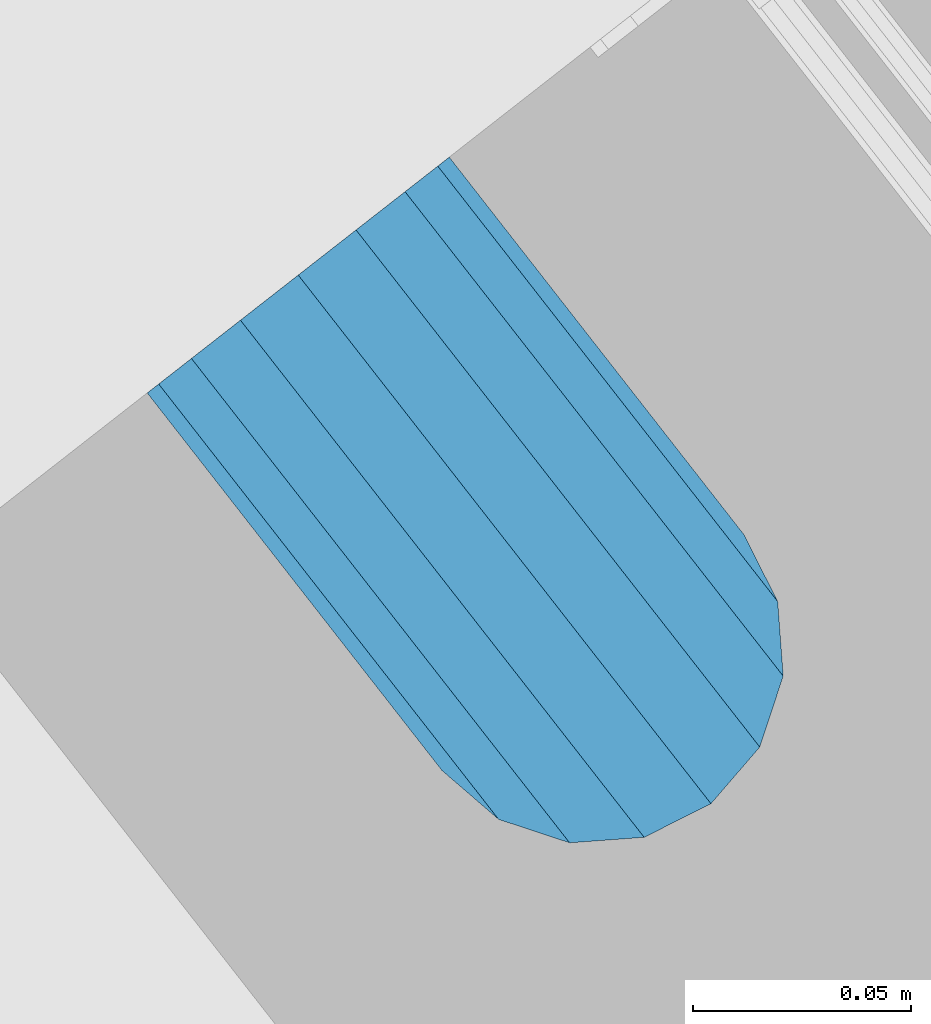
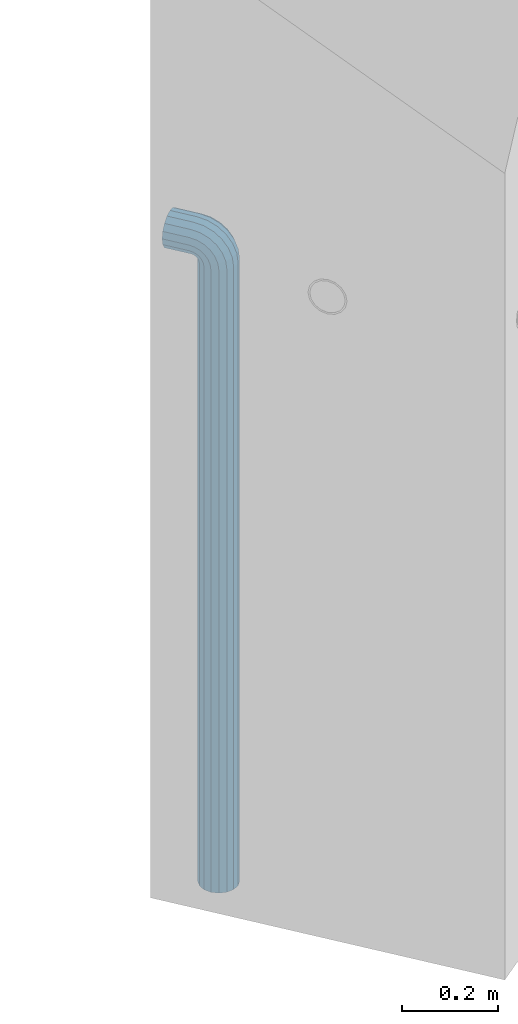
# One storey, part 3 of 42: 1 beam, 2 elements without a shape of their own.
"""IFC2X3 building model written with IfcOpenShell, lengths in millimetres."""

from ifc_helpers import new_model, si_unit, frame, origin_with_axes, place, context, subcontext, project, spatial, faceted_brep, material, type_object, element, aggregate, save


model = new_model("IFC2X3")

# Units and contexts
model_context = context("Model", 3, precision=1e-05, world=origin_with_axes())
body_context = subcontext(model_context, "Body", "Model", "MODEL_VIEW")
ifc_project = project(units=[si_unit("LENGTHUNIT", "METRE", prefix="MILLI"), si_unit("AREAUNIT", "SQUARE_METRE"), si_unit("VOLUMEUNIT", "CUBIC_METRE"), si_unit("MASSUNIT", "GRAM", prefix="KILO"), si_unit("TIMEUNIT", "SECOND"), si_unit("PLANEANGLEUNIT", "RADIAN"), si_unit("SOLIDANGLEUNIT", "STERADIAN"), si_unit("THERMODYNAMICTEMPERATUREUNIT", "DEGREE_CELSIUS"), si_unit("LUMINOUSINTENSITYUNIT", "LUMEN")], contexts=[model_context])

# Site, building, storey
site_placement = place(None, frame((171687.4, 84828.52, 14700.0), z_axis=(0.0, 0.0, 1.0), x_axis=(1.0, 0.0, 0.0)))
site = spatial("IfcSite", under=ifc_project, at=site_placement, CompositionType="ELEMENT")
building_placement = place(site_placement, origin_with_axes())
building = spatial("IfcBuilding", under=site, at=building_placement, Name="Undefined", CompositionType="ELEMENT")
storey_placement = place(building_placement, origin_with_axes())
storey = spatial("IfcBuildingStorey", under=building, at=storey_placement, Name="Undefined", CompositionType="ELEMENT", Elevation=0.0)

# Assemblies, beam
assembly_1_placement = place(storey_placement, origin_with_axes())
assembly_1 = element("IfcElementAssembly", 1, at=assembly_1_placement, inside=storey, AssemblyPlace="NOTDEFINED", PredefinedType="REINFORCEMENT_UNIT")
assembly_2_placement = place(assembly_1_placement, origin_with_axes())
assembly_2 = element("IfcElementAssembly", 2, at=assembly_2_placement, AssemblyPlace="NOTDEFINED", PredefinedType="RIGID_FRAME")
aggregate(assembly_1, [assembly_2])
ifc_material = material(Name="STEEL/NEG_BETON")
beam_type = type_object("IfcBeamType", PredefinedType="NOTDEFINED")
beam_placement = place(assembly_2_placement, frame((17827.6776781408, 265507.104402164, -1290.0), z_axis=(0.615386370178831, -0.788225611990706, 0.0), x_axis=(0.0, 0.0, 1.0)))
beam = element("IfcBeam", 3, at=beam_placement, type_object=beam_type, material=ifc_material, context=body_context, shape_type="Brep", body=[
    faceted_brep([(0.0, -43.999999753345, 2.88331648334861e-07), (0.0, -40.6506991838105, -16.8380707357428), (1590.0, -40.6506991838105, -16.8380707357428), (1589.99999999999, -43.999999753345, 2.88331648334861e-07), (0.0, -31.1126981254783, -31.1126980838017), (1590.0, -31.1126981254783, -31.1126980838017), (0.0, -16.8380707773322, -40.6506991419883), (1590.0, -16.8380707773322, -40.6506991419883), (0.0, 2.46742274612188e-07, -43.9999997114064), (1590.0, 2.46742274612188e-07, -43.9999997114064), (0.0, 16.8380712707876, -40.6506991418137), (1590.0, 16.8380712707876, -40.6506991418137), (0.0, 31.1126986189047, -31.1126980834524), (1590.0, 31.1126986189047, -31.1126980834524), (0.0, 40.6506996771204, -16.8380707352771), (1590.0, 40.6506996771204, -16.8380707352771), (0.0, 44.0000002465677, 2.88768205791712e-07), (1590.0, 44.0000002465677, 2.88768205791712e-07), (0.0, 40.6506996770622, 16.8380713128427), (1590.0, 40.6506996770622, 16.8380713128427), (0.0, 31.1126986187301, 31.1126986609306), (1590.0, 31.1126986187301, 31.1126986609306), (0.0, 16.8380712705839, 40.6506997191464), (1590.0, 16.8380712705839, 40.6506997191464), (0.0, 2.46509443968534e-07, 44.0000002885354), (1590.0, 2.46509443968534e-07, 44.0000002885354), (0.0, -16.8380707775359, 40.6506997189426), (1590.0, -16.8380707775359, 40.6506997189426), (0.0, -31.1126981256821, 31.1126986605814), (1590.0, -31.1126981256821, 31.1126986605814), (0.0, -40.6506991838978, 16.838071312377), (1590.0, -40.6506991838978, 16.838071312377), (4.47878846898675e-07, -40.0000000634464, 0.0), (4.47878846898675e-07, -36.9551813638827, 15.3073372946019), (1590.0, -36.9551810538396, 15.3073375829845), (1589.99999999999, -39.999999753345, 2.88360752165318e-07), (4.47937054559588e-07, -28.2842713108694, 28.284271247463), (1590.0, -28.2842710008845, 28.2842715359002), (4.4800981413573e-07, -15.3073373580119, 36.9551813004509), (1590.0, -15.3073370480561, 36.9551815889135), (4.48068021796644e-07, -6.34463503956795e-08, 40.0), (1590.0, 2.46538547798991e-07, 40.0000002885645), (4.48140781372786e-07, 15.3073372311774, 36.9551813004509), (1590.0, 15.3073375411332, 36.9551815890882), (4.48213540948927e-07, 28.2842711840058, 28.284271247463), (1590.0, 28.2842714939907, 28.2842715361621), (4.48271748609841e-07, 36.95518123699, 15.3073372946019), (1590.0, 36.9551815469749, 15.3073375833046), (4.48286300525069e-07, 39.9999999365536, 0.0), (1590.0, 40.0000002465677, 2.88768205791712e-07), (4.48271748609841e-07, 36.95518123699, -15.3073372946019), (1590.0, 36.9551815470913, -15.3073370058555), (4.48213540948927e-07, 28.2842711840058, -28.284271247463), (1590.0, 28.2842714941071, -28.2842709587712), (4.48140781372786e-07, 15.3073372311774, -36.9551813004509), (1590.0, 15.3073375413369, -36.9551810117846), (4.48068021796644e-07, -6.34463503956795e-08, -40.0), (1590.0, 2.46742274612188e-07, -39.9999997114064), (4.4800981413573e-07, -15.3073373580119, -36.9551813004509), (1590.0, -15.3073370479106, -36.9551810119592), (4.47937054559588e-07, -28.2842713108694, -28.284271247463), (1590.0, -28.284271000739, -28.2842709590332), (4.47878846898675e-07, -36.9551813638827, -15.3073372946019), (1590.0, -36.9551810537523, -15.3073370062048), (1602.94095225512, -43.9999997526465, -1.70370839745738), (1607.29896571893, -40.6506991831702, 14.560619269585), (1610.99351113838, -31.1126981249254, 28.3488504858688), (1613.46212746447, -16.8380707768374, 37.5618520393036), (1614.32899023963, 2.47237039729953e-07, 40.7970279594592), (1613.46212746447, 16.8380712712533, 37.5618520394491), (1610.99351113838, 31.1126986194577, 28.3488504861598), (1607.29896571893, 40.6506996777607, 14.5606192699925), (1602.94095225512, 44.0000002472952, -1.70370839699171), (1598.5829387913, 40.650699677848, -17.9680360640341), (1594.88839337186, 31.1126986196032, -31.7562672803178), (1592.41977704577, 16.8380712714861, -40.9692688337527), (1591.55291427061, 2.4744076654315e-07, -44.2044447539374), (1592.41977704577, -16.8380707766337, -40.9692688339564), (1594.88839337186, -31.1126981247508, -31.7562672806089), (1598.5829387913, -40.6506991830829, -17.9680360644415), (1613.29371405922, 2.47237039729953e-07, 36.9333246542956), (1612.50565699089, -15.3073370473576, 33.992255635967), (1610.26146033081, -28.284271000186, 25.6167996783042), (1606.90278267677, -36.9551810531411, 13.0820440271636), (1602.94095225512, -39.9999997526465, -1.70370839745738), (1598.97912183347, -36.9551810530538, -16.4894608219911), (1595.62044417943, -28.2842710000114, -29.0242164730153), (1593.37624751934, -15.3073370471539, -37.3996724305616), (1592.58819045102, 2.47411662712693e-07, -40.3407414487447), (1593.37624751934, 15.3073375420063, -37.3996724304452), (1595.62044417943, 28.2842714948347, -29.0242164727533), (1598.97912183347, 36.9551815478189, -16.4894608215836), (1602.94095225512, 40.0000002472952, -1.70370839699171), (1606.90278267677, 36.9551815477316, 13.082044027542), (1610.26146033081, 28.2842714946892, 25.6167996785662), (1612.50565699089, 15.3073375418317, 33.9922556361125), (1630.55634918609, -31.1126981248963, 20.2456576479599), (1635.32534971524, -16.8380707767792, 28.5058088658843), (1623.41903551202, -40.6506991831702, 7.88346773487865), (1614.99999999999, -43.9999997526465, -6.69872952270089), (1606.58096448796, -40.6506991830829, -21.2809267801931), (1599.44365081389, -31.1126981247799, -33.6431166932161), (1594.67465028474, -16.8380707766337, -41.9032679109368), (1592.99999999999, 2.4744076654315e-07, -44.8038472889457), (1594.67465028474, 16.8380712714861, -41.9032679107622), (1599.44365081389, 31.1126986195741, -33.6431166929251), (1606.58096448796, 40.650699677848, -21.2809267798148), (1614.99999999999, 44.0000002472952, -6.69872952226433), (1623.41903551202, 40.6506996777898, 7.88346773531521), (1630.55634918609, 31.1126986194577, 20.24565764828), (1635.32534971524, 16.8380712713115, 28.5058088660007), (1636.99999999999, 2.4726614356041e-07, 31.4063882440387), (1633.47759065022, 15.3073375418608, 25.3053962852573), (1634.99999999999, 2.4726614356041e-07, 27.9422866288805), (1629.14213562372, 28.2842714947183, 17.7961679055006), (1622.65366864729, 36.9551815477607, 6.55781343916897), (1614.99999999999, 40.0000002473244, -6.69872952226433), (1607.34633135269, 36.9551815477898, -19.9552724836976), (1600.85786437626, 28.2842714948347, -31.1936269501166), (1596.52240934976, 15.3073375420354, -38.7028553300188), (1594.99999999999, 2.47411662712693e-07, -41.3397456738458), (1596.52240934976, -15.3073370471539, -38.7028553301352), (1600.85786437626, -28.2842710000696, -31.1936269504367), (1607.34633135269, -36.9551810530538, -19.9552724840469), (1614.99999999999, -39.9999997526465, -6.69872952267178), (1622.65366864729, -36.955181053112, 6.55781343879062), (1629.14213562372, -28.2842710001278, 17.7961679052387), (1633.47759065022, -15.3073370472994, 25.3053962851118), (1647.35533905931, -31.1126981248963, 7.35533934747218), (1654.09972428659, -16.8380707767792, 14.0997245748003), (1637.26165326253, -40.6506991831411, -2.73834644936142), (1625.35533905931, -43.9999997526174, -14.644660652586), (1613.4490248561, -40.650699183112, -26.5509748557815), (1603.35533905931, -31.1126981247508, -36.6446606524696), (1596.61095383203, -16.8380707766046, -43.3890458796814), (1594.24264068711, 2.4744076654315e-07, -45.7573590245447), (1596.61095383203, 16.8380712714861, -43.3890458795358), (1603.35533905931, 31.1126986196032, -36.6446606521786), (1613.4490248561, 40.6506996778771, -26.550974855345), (1625.35533905931, 44.0000002473244, -14.6446606521204), (1637.26165326253, 40.6506996778189, -2.73834644892486), (1647.35533905931, 31.1126986194868, 7.35533934779232), (1654.09972428659, 16.8380712713406, 14.0997245750041), (1656.46803743151, 2.47295247390866e-07, 16.4680377198383), (1651.48659835683, 15.3073375418899, 11.4865986451914), (1653.63961030677, 2.47295247390866e-07, 13.6396105950989), (1645.35533905931, 28.2842714947474, 5.35533934776322), (1636.17926106223, 36.9551815477607, -3.82073864925769), (1625.35533905931, 40.0000002473244, -14.6446606521204), (1614.53141705639, 36.9551815478189, -25.4685826550995), (1605.35533905931, 28.2842714948638, -34.6446606522077), (1599.22407976179, 15.3073375420063, -40.7759199497814), (1597.07106781185, 2.4744076654315e-07, -42.9289318997762), (1599.22407976179, -15.3073370471539, -40.7759199499269), (1605.35533905931, -28.2842710000405, -34.6446606524696), (1614.53141705639, -36.9551810530247, -25.4685826554487), (1625.35533905931, -39.9999997526174, -14.644660652586), (1636.17926106223, -36.9551810530829, -3.82073864963604), (1645.35533905931, -28.2842710001278, 5.35533934750129), (1651.48659835683, -15.3073370472994, 11.486598645075), (1660.24565735981, -31.1126981248381, -9.44365052573266), (1668.50580857761, -16.838070776721, -4.67464999653748), (1647.88346744676, -40.6506991830829, -16.5809641998203), (1633.3012701892, -43.9999997525592, -24.9999997119012), (1618.71907293164, -40.6506991830538, -33.4190352238948), (1606.35688301859, -31.1126981247508, -40.5563488978951), (1598.09673180079, -16.8380707766337, -45.3253494270029), (1595.19615242269, 2.47469870373607e-07, -46.9999997116392), (1598.09673180079, 16.8380712714861, -45.3253494267992), (1606.35688301859, 31.1126986196032, -40.556348897604), (1618.71907293164, 40.6506996778771, -33.4190352235164), (1633.3012701892, 44.0000002473535, -24.9999997114355), (1647.88346744676, 40.650699677848, -16.580964199442), (1660.24565735981, 31.1126986195159, -9.44365052544163), (1668.50580857761, 16.8380712713988, -4.67464999633376), (1671.40638795571, 2.47324351221323e-07, -2.99999971169746), (1665.30539599684, 15.307337541919, -6.52240906140651), (1667.94228634057, 2.47324351221323e-07, -4.99999971172656), (1657.79616761703, 28.2842714948056, -10.8578640878259), (1646.55781315062, 36.9551815477898, -17.3463310641819), (1633.3012701892, 40.0000002473826, -24.9999997114355), (1620.04472722778, 36.955181547848, -32.6536683587765), (1608.80637276137, 28.2842714948638, -39.1421353352489), (1601.29714438156, 15.3073375420063, -43.4775903618138), (1598.66025403783, 2.47469870373607e-07, -44.9999997116392), (1601.29714438156, -15.3073370471539, -43.4775903619302), (1608.80637276137, -28.2842710000114, -39.1421353355108), (1620.04472722778, -36.9551810530247, -32.6536683591548), (1633.3012701892, -39.9999997525883, -24.9999997119012), (1646.55781315062, -36.9551810530538, -17.3463310645602), (1657.79616761703, -28.2842710000987, -10.8578640880878), (1665.30539599684, -15.3073370472412, -6.52240906155203), (1668.34885019768, -31.1126981247799, -29.0064885734755), (1677.56185175105, -16.8380707766628, -26.5378722472815), (1654.56061898146, -40.6506991830538, -32.7010339929548), (1638.29629131443, -43.9999997525592, -37.0590474567725), (1622.0319636474, -40.6506991830538, -41.4170609205903), (1608.24373243118, -31.1126981247508, -45.111606339924), (1599.03073087781, -16.8380707766046, -47.5802226659725), (1595.79555495772, 2.47469870373607e-07, -48.447085441032), (1599.03073087781, 16.8380712715152, -47.5802226657979), (1608.24373243118, 31.1126986196032, -45.1116063396621), (1622.0319636474, 40.6506996779062, -41.4170609201537), (1638.29629131443, 44.0000002474117, -37.059047456336), (1654.56061898146, 40.6506996778771, -32.7010339925182), (1668.34885019768, 31.112698619545, -29.0064885731554), (1677.56185175105, 16.8380712714279, -26.537872247136), (1680.79702767114, 2.47382558882236e-07, -25.6710094720474), (1673.99225534772, 15.3073375420063, -27.494342720689), (1676.93332436598, 2.47382558882236e-07, -26.7062856524717), (1665.61679939011, 28.2842714948056, -29.738539380749), (1653.082043739, 36.9551815478189, -33.0972170347231), (1638.29629131443, 40.0000002473826, -37.059047456336), (1623.51053888986, 36.955181547848, -41.0208778779779), (1610.97578323875, 28.2842714948929, -44.3795555320976), (1602.60032728114, 15.3073375420354, -46.6237521922449), (1599.65925826287, 2.4744076654315e-07, -47.4118092606659), (1602.60032728114, -15.3073370471539, -46.6237521923613), (1610.97578323875, -28.2842710000114, -44.3795555323595), (1623.51053888986, -36.9551810529956, -41.0208778783854), (1638.29629131443, -39.9999997525592, -37.0590474567725), (1653.082043739, -36.9551810529956, -33.0972170350724), (1665.61679939011, -28.2842710000405, -29.73853938104), (1673.99225534772, -15.3073370472121, -27.4943427208927), (1608.88730162777, -31.1126981247216, -49.9999997117848), (1623.16192897591, -40.6506991830247, -49.9999997118721), (1599.34930056949, -16.8380707766046, -49.9999997117557), (1595.99999999998, 2.47469870373607e-07, -49.9999997116684), (1599.34930056949, 16.8380712715152, -49.9999997115519), (1608.88730162777, 31.1126986196323, -49.9999997115228), (1623.16192897591, 40.6506996779353, -49.9999997114355), (1639.99999999997, 44.0000002473826, -49.9999997114646), (1656.83807102403, 40.6506996779353, -49.9999997114355), (1671.11269837217, 31.1126986196323, -49.9999997115228), (1680.65069943045, 16.8380712715152, -49.9999997115519), (1683.99999999996, 2.47469870373607e-07, -49.9999997116684), (1680.65069943045, -16.8380707766046, -49.9999997117557), (1671.11269837217, -31.1126981247216, -49.9999997117848), (1656.83807102403, -40.6506991830247, -49.9999997118721), (1640.0, -43.999999752501, -49.9999997118721), (1676.95518130041, 15.3073375420354, -49.9999997116101), (1679.99999999996, 2.47469870373607e-07, -49.9999997116684), (1668.28427124742, 28.2842714948929, -49.9999997114937), (1655.30733729457, 36.9551815478771, -49.9999997114937), (1639.99999999997, 40.0000002474117, -49.9999997114937), (1624.69266270537, 36.9551815478771, -49.9999997114937), (1611.71572875252, 28.2842714948929, -49.9999997114937), (1603.04481869953, 15.3073375420354, -49.9999997116101), (1599.99999999998, 2.47469870373607e-07, -49.9999997116684), (1603.04481869953, -15.3073370471539, -49.9999997117266), (1611.71572875252, -28.2842710000114, -49.9999997118139), (1624.69266270537, -36.9551810529665, -49.9999997118139), (1640.0, -39.9999997525301, -49.999999711843), (1655.30733729457, -36.9551810529665, -49.999999711843), (1668.28427124742, -28.2842710000114, -49.9999997118139), (1676.95518130041, -15.3073370471247, -49.9999997117266), (1623.16192897594, -40.6506991828792, -109.999999711843), (1640.0, -43.9999997523555, -109.999999711843), (1608.88730162779, -31.1126981245761, -109.999999711785), (1599.3493005695, -16.8380707764591, -109.999999711727), (1596.0, 2.4761538952589e-07, -109.999999711639), (1599.3493005695, 16.8380712716607, -109.999999711552), (1608.88730162779, 31.1126986197778, -109.999999711494), (1623.16192897594, 40.6506996780809, -109.999999711406), (1640.0, 44.0000002475572, -109.999999711436), (1656.83807102406, 40.6506996780809, -109.999999711406), (1671.11269837221, 31.1126986197778, -109.999999711494), (1680.6506994305, 16.8380712716607, -109.999999711552), (1684.0, 2.4761538952589e-07, -109.999999711639), (1680.6506994305, -16.8380707764591, -109.999999711727), (1671.11269837221, -31.1126981245761, -109.999999711785), (1656.83807102406, -40.6506991828792, -109.999999711843), (1655.3073372946, -36.9551810527919, -109.999999711785), (1640.0, -39.9999997523846, -109.999999711843), (1668.28427124746, -28.2842709998658, -109.999999711785), (1676.95518130045, -15.3073370469792, -109.999999711727), (1680.0, 2.4761538952589e-07, -109.999999711639), (1676.95518130045, 15.3073375421809, -109.999999711581), (1668.28427124746, 28.2842714950675, -109.999999711465), (1655.3073372946, 36.9551815479936, -109.999999711465), (1640.0, 40.0000002475572, -109.999999711465), (1624.6926627054, 36.9551815479936, -109.999999711465), (1611.71572875254, 28.2842714950675, -109.999999711465), (1603.04481869955, 15.3073375421809, -109.999999711581), (1600.0, 2.4761538952589e-07, -109.999999711639), (1603.04481869955, -15.3073370469792, -109.999999711727), (1611.71572875254, -28.2842709998658, -109.999999711785), (1624.6926627054, -36.9551810527919, -109.999999711785)], [[[0, 1, 2, 3]], [[1, 4, 5, 2]], [[4, 6, 7, 5]], [[6, 8, 9, 7]], [[8, 10, 11, 9]], [[10, 12, 13, 11]], [[12, 14, 15, 13]], [[14, 16, 17, 15]], [[16, 18, 19, 17]], [[18, 20, 21, 19]], [[20, 22, 23, 21]], [[22, 24, 25, 23]], [[24, 26, 27, 25]], [[26, 28, 29, 27]], [[28, 30, 31, 29]], [[30, 0, 3, 31]], [[32, 33, 34, 35]], [[33, 36, 37, 34]], [[36, 38, 39, 37]], [[38, 40, 41, 39]], [[40, 42, 43, 41]], [[42, 44, 45, 43]], [[44, 46, 47, 45]], [[46, 48, 49, 47]], [[48, 50, 51, 49]], [[50, 52, 53, 51]], [[52, 54, 55, 53]], [[54, 56, 57, 55]], [[56, 58, 59, 57]], [[58, 60, 61, 59]], [[60, 62, 63, 61]], [[62, 32, 35, 63]], [[30, 28, 26, 24, 22, 20, 18, 16, 14, 12, 10, 8, 6, 4, 1, 0], [62, 60, 58, 56, 54, 52, 50, 48, 46, 44, 42, 40, 38, 36, 33, 32]], [[31, 3, 64, 65]], [[29, 31, 65, 66]], [[27, 29, 66, 67]], [[25, 27, 67, 68]], [[23, 25, 68, 69]], [[21, 23, 69, 70]], [[19, 21, 70, 71]], [[17, 19, 71, 72]], [[15, 17, 72, 73]], [[13, 15, 73, 74]], [[11, 13, 74, 75]], [[9, 11, 75, 76]], [[7, 9, 76, 77]], [[5, 7, 77, 78]], [[2, 5, 78, 79]], [[3, 2, 79, 64]], [[39, 41, 80, 81]], [[37, 39, 81, 82]], [[34, 37, 82, 83]], [[35, 34, 83, 84]], [[63, 35, 84, 85]], [[61, 63, 85, 86]], [[59, 61, 86, 87]], [[57, 59, 87, 88]], [[55, 57, 88, 89]], [[53, 55, 89, 90]], [[51, 53, 90, 91]], [[49, 51, 91, 92]], [[47, 49, 92, 93]], [[45, 47, 93, 94]], [[43, 45, 94, 95]], [[41, 43, 95, 80]], [[66, 96, 97, 67]], [[65, 98, 96, 66]], [[64, 99, 98, 65]], [[79, 100, 99, 64]], [[78, 101, 100, 79]], [[77, 102, 101, 78]], [[76, 103, 102, 77]], [[75, 104, 103, 76]], [[74, 105, 104, 75]], [[73, 106, 105, 74]], [[72, 107, 106, 73]], [[71, 108, 107, 72]], [[70, 109, 108, 71]], [[69, 110, 109, 70]], [[68, 111, 110, 69]], [[67, 97, 111, 68]], [[95, 112, 113, 80]], [[94, 114, 112, 95]], [[93, 115, 114, 94]], [[92, 116, 115, 93]], [[91, 117, 116, 92]], [[90, 118, 117, 91]], [[89, 119, 118, 90]], [[88, 120, 119, 89]], [[87, 121, 120, 88]], [[86, 122, 121, 87]], [[85, 123, 122, 86]], [[84, 124, 123, 85]], [[83, 125, 124, 84]], [[82, 126, 125, 83]], [[81, 127, 126, 82]], [[80, 113, 127, 81]], [[96, 128, 129, 97]], [[98, 130, 128, 96]], [[99, 131, 130, 98]], [[100, 132, 131, 99]], [[101, 133, 132, 100]], [[102, 134, 133, 101]], [[103, 135, 134, 102]], [[104, 136, 135, 103]], [[105, 137, 136, 104]], [[106, 138, 137, 105]], [[107, 139, 138, 106]], [[108, 140, 139, 107]], [[109, 141, 140, 108]], [[110, 142, 141, 109]], [[111, 143, 142, 110]], [[97, 129, 143, 111]], [[112, 144, 145, 113]], [[114, 146, 144, 112]], [[115, 147, 146, 114]], [[116, 148, 147, 115]], [[117, 149, 148, 116]], [[118, 150, 149, 117]], [[119, 151, 150, 118]], [[120, 152, 151, 119]], [[121, 153, 152, 120]], [[122, 154, 153, 121]], [[123, 155, 154, 122]], [[124, 156, 155, 123]], [[125, 157, 156, 124]], [[126, 158, 157, 125]], [[127, 159, 158, 126]], [[113, 145, 159, 127]], [[128, 160, 161, 129]], [[130, 162, 160, 128]], [[131, 163, 162, 130]], [[132, 164, 163, 131]], [[133, 165, 164, 132]], [[134, 166, 165, 133]], [[135, 167, 166, 134]], [[136, 168, 167, 135]], [[137, 169, 168, 136]], [[138, 170, 169, 137]], [[139, 171, 170, 138]], [[140, 172, 171, 139]], [[141, 173, 172, 140]], [[142, 174, 173, 141]], [[143, 175, 174, 142]], [[129, 161, 175, 143]], [[144, 176, 177, 145]], [[146, 178, 176, 144]], [[147, 179, 178, 146]], [[148, 180, 179, 147]], [[149, 181, 180, 148]], [[150, 182, 181, 149]], [[151, 183, 182, 150]], [[152, 184, 183, 151]], [[153, 185, 184, 152]], [[154, 186, 185, 153]], [[155, 187, 186, 154]], [[156, 188, 187, 155]], [[157, 189, 188, 156]], [[158, 190, 189, 157]], [[159, 191, 190, 158]], [[145, 177, 191, 159]], [[160, 192, 193, 161]], [[162, 194, 192, 160]], [[163, 195, 194, 162]], [[164, 196, 195, 163]], [[165, 197, 196, 164]], [[166, 198, 197, 165]], [[167, 199, 198, 166]], [[168, 200, 199, 167]], [[169, 201, 200, 168]], [[170, 202, 201, 169]], [[171, 203, 202, 170]], [[172, 204, 203, 171]], [[173, 205, 204, 172]], [[174, 206, 205, 173]], [[175, 207, 206, 174]], [[161, 193, 207, 175]], [[176, 208, 209, 177]], [[178, 210, 208, 176]], [[179, 211, 210, 178]], [[180, 212, 211, 179]], [[181, 213, 212, 180]], [[182, 214, 213, 181]], [[183, 215, 214, 182]], [[184, 216, 215, 183]], [[185, 217, 216, 184]], [[186, 218, 217, 185]], [[187, 219, 218, 186]], [[188, 220, 219, 187]], [[189, 221, 220, 188]], [[190, 222, 221, 189]], [[191, 223, 222, 190]], [[177, 209, 223, 191]], [[197, 224, 225, 196]], [[198, 226, 224, 197]], [[199, 227, 226, 198]], [[200, 228, 227, 199]], [[201, 229, 228, 200]], [[202, 230, 229, 201]], [[203, 231, 230, 202]], [[204, 232, 231, 203]], [[205, 233, 232, 204]], [[206, 234, 233, 205]], [[207, 235, 234, 206]], [[193, 236, 235, 207]], [[192, 237, 236, 193]], [[194, 238, 237, 192]], [[195, 239, 238, 194]], [[196, 225, 239, 195]], [[208, 240, 241, 209]], [[210, 242, 240, 208]], [[211, 243, 242, 210]], [[212, 244, 243, 211]], [[213, 245, 244, 212]], [[214, 246, 245, 213]], [[215, 247, 246, 214]], [[216, 248, 247, 215]], [[217, 249, 248, 216]], [[218, 250, 249, 217]], [[219, 251, 250, 218]], [[220, 252, 251, 219]], [[221, 253, 252, 220]], [[222, 254, 253, 221]], [[223, 255, 254, 222]], [[209, 241, 255, 223]], [[239, 225, 256, 257]], [[225, 224, 258, 256]], [[224, 226, 259, 258]], [[226, 227, 260, 259]], [[227, 228, 261, 260]], [[228, 229, 262, 261]], [[229, 230, 263, 262]], [[230, 231, 264, 263]], [[231, 232, 265, 264]], [[232, 233, 266, 265]], [[233, 234, 267, 266]], [[234, 235, 268, 267]], [[235, 236, 269, 268]], [[236, 237, 270, 269]], [[237, 238, 271, 270]], [[238, 239, 257, 271]], [[252, 253, 272, 273]], [[253, 254, 274, 272]], [[254, 255, 275, 274]], [[255, 241, 276, 275]], [[241, 240, 277, 276]], [[240, 242, 278, 277]], [[242, 243, 279, 278]], [[243, 244, 280, 279]], [[244, 245, 281, 280]], [[245, 246, 282, 281]], [[246, 247, 283, 282]], [[247, 248, 284, 283]], [[248, 249, 285, 284]], [[249, 250, 286, 285]], [[250, 251, 287, 286]], [[251, 252, 273, 287]], [[258, 259, 260, 261, 262, 263, 264, 265, 266, 267, 268, 269, 270, 271, 257, 256], [274, 275, 276, 277, 278, 279, 280, 281, 282, 283, 284, 285, 286, 287, 273, 272]]]),
])
aggregate(assembly_2, [beam])

save(model, "model.ifc")
